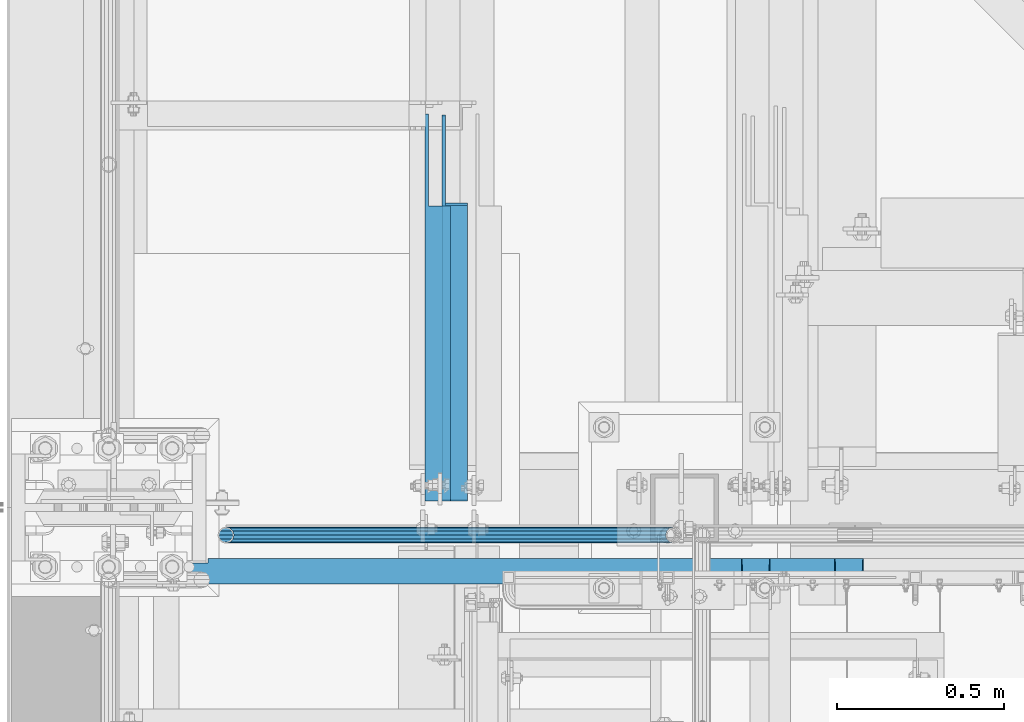
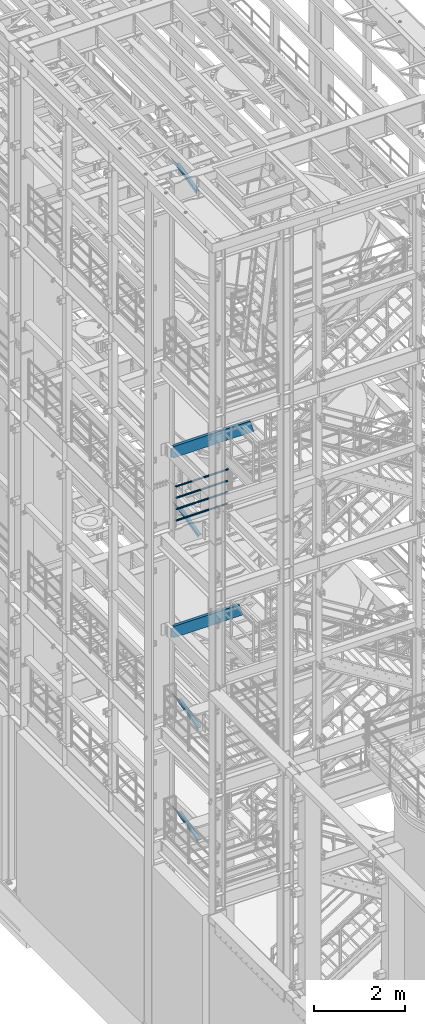
# One storey, part 963 of 1876: 10 beams, 7 elements without a shape of their own.
"""IFC2X3 building model written with IfcOpenShell, lengths in millimetres."""

from ifc_helpers import new_model, si_unit, frame, origin_with_axes, place, context, subcontext, project, spatial, faceted_brep, material, type_object, element, aggregate, save


model = new_model("IFC2X3")

# Units and contexts
model_context = context("Model", 3, precision=1e-05, world=origin_with_axes())
body_context = subcontext(model_context, "Body", "Model", "MODEL_VIEW")
ifc_project = project(units=[si_unit("LENGTHUNIT", "METRE", prefix="MILLI"), si_unit("AREAUNIT", "SQUARE_METRE"), si_unit("VOLUMEUNIT", "CUBIC_METRE"), si_unit("MASSUNIT", "GRAM", prefix="KILO"), si_unit("TIMEUNIT", "SECOND"), si_unit("PLANEANGLEUNIT", "RADIAN"), si_unit("SOLIDANGLEUNIT", "STERADIAN"), si_unit("THERMODYNAMICTEMPERATUREUNIT", "DEGREE_CELSIUS"), si_unit("LUMINOUSINTENSITYUNIT", "LUMEN")], contexts=[model_context])

# Site, building, storey
site_placement = place(None, origin_with_axes())
site = spatial("IfcSite", under=ifc_project, at=site_placement, CompositionType="ELEMENT")
building_placement = place(site_placement, origin_with_axes())
building = spatial("IfcBuilding", under=site, at=building_placement, Name="Undefined", CompositionType="ELEMENT")
storey_placement = place(building_placement, origin_with_axes())
storey = spatial("IfcBuildingStorey", under=building, at=storey_placement, Name="Undefined", CompositionType="ELEMENT", Elevation=0.0)

# Assembly, beams
assembly_1_placement = place(storey_placement, origin_with_axes())
assembly_1 = element("IfcElementAssembly", 1, at=assembly_1_placement, inside=storey, Name="RAIL", AssemblyPlace="NOTDEFINED", PredefinedType="RIGID_FRAME")
ifc_material_1 = material()
beam_type_1 = type_object("IfcBeamType", Name="PIPE1-1/2SCH40", PredefinedType="NOTDEFINED")
beam_1_placement = place(assembly_1_placement, frame((351.789999999999, -4654.55000114554, 13471.525), z_axis=(0.0, 0.0, 1.0), x_axis=(1.0, 0.0, 0.0)))
beam_1 = element("IfcBeam", 2, at=beam_1_placement, type_object=beam_type_1, material=ifc_material_1, Name="RAIL", ObjectType="PIPE1-1/2SCH40", context=body_context, shape_type="Brep", body=[
    faceted_brep([(1322.12780700668, -12.0649999999996, 20.8971929933186), (1322.12780700668, -12.0649999999996, 15.8661214311805), (1321.63437856882, -10.2235000000001, 17.7076214311801), (1318.895, 0.0, 20.4470000000001), (1318.895, 0.0, 24.1300000000001), (1321.63437856882, 10.2235000000001, 17.7076214311801), (1322.12780700668, 12.0649999999996, 15.8661214311805), (1322.12780700668, 12.0649999999996, 20.8971929933186), (1343.025, 24.1300000000001, 0.0), (1330.96, 20.8971929933186, 12.0649999999996), (1330.96, 20.8971929933186, -12.0649999999996), (1327.77042843786, 17.7076214311801, 10.2235000000001), (1330.50980700668, 20.4470000000001, 0.0), (1327.77042843786, 17.7076214311801, -10.2235000000001), (1322.12780700668, 12.0649999999996, -15.8661214311805), (1322.12780700668, 12.0649999999996, -20.8971929933186), (1321.63437856882, 10.2235000000001, -17.7076214311801), (1318.895, 0.0, -20.4470000000001), (1318.895, 0.0, -24.1300000000001), (1322.12780700668, -12.0649999999996, -15.8661214311805), (1322.12780700668, -12.0649999999996, -20.8971929933186), (1321.63437856882, -10.2235000000001, -17.7076214311801), (1343.025, -24.1300000000001, 0.0), (1330.96, -20.8971929933186, -12.0649999999996), (1330.96, -20.8971929933186, 12.0649999999996), (1327.77042843786, -17.7076214311801, -10.2235000000001), (1330.50980700668, -20.4470000000001, 0.0), (1327.77042843786, -17.7076214311801, 10.2235000000001), (12.0650000000064, -20.8971929933177, -12.0649999999987), (20.8971929933249, -12.0650000000005, -20.8971929933177), (0.0, 24.1299999999992, 0.0), (12.0650000000064, 20.8971929933177, -12.0649999999987), (12.0650000000064, 20.8971929933177, 12.0649999999987), (20.8971929933249, 12.0650000000005, 20.8971929933177), (24.1300000000064, 0.0, 24.130000000001), (20.8971929933249, 12.0650000000005, -20.8971929933177), (24.1300000000063, 0.0, -24.130000000001), (24.1300000000063, 0.0, -20.4470000000001), (20.8971929933249, -12.0650000000005, -15.8661214311796), (21.3906214311868, -10.2235000000001, -17.7076214311819), (21.3906214311868, 10.2235000000001, -17.7076214311819), (20.8971929933249, 12.0650000000005, -15.8661214311796), (15.2545715621445, 17.7076214311801, -10.2235000000001), (12.5151929933249, 20.4470000000001, 0.0), (15.2545715621445, 17.7076214311801, 10.2235000000001), (20.8971929933249, 12.0650000000005, 15.8661214311796), (21.3906214311868, 10.2235000000001, 17.7076214311819), (24.1300000000064, 0.0, 20.4470000000001), (21.3906214311868, -10.2235000000001, 17.7076214311819), (20.8971929933249, -12.0650000000005, 15.8661214311796), (20.8971929933249, -12.0650000000005, 20.8971929933177), (12.0650000000064, -20.8971929933177, 12.0649999999987), (0.0, -24.1299999999992, 0.0), (15.2545715621445, -17.7076214311801, 10.2235000000001), (12.5151929933249, -20.4470000000001, 0.0), (15.2545715621445, -17.7076214311801, -10.2235000000001)], [[[0, 1, 2, 3, 4]], [[4, 3, 5, 6, 7]], [[8, 9, 10]], [[7, 6, 11, 12, 13, 14, 15, 10, 9]], [[16, 17, 18, 15, 14]], [[19, 20, 18, 17, 21]], [[22, 23, 24]], [[24, 23, 20, 19, 25, 26, 27, 1, 0]], [[28, 29, 20, 23]], [[30, 31, 32]], [[33, 34, 4, 7]], [[32, 33, 7, 9]], [[30, 32, 9, 8]], [[31, 30, 8, 10]], [[35, 31, 10, 15]], [[36, 35, 15, 18]], [[29, 36, 18, 20]], [[37, 36, 29, 38, 39]], [[40, 41, 35, 36, 37]], [[32, 31, 35, 41, 42, 43, 44, 45, 33]], [[33, 45, 46, 47, 34]], [[34, 47, 48, 49, 50]], [[34, 50, 0, 4]], [[50, 51, 24, 0]], [[51, 52, 22, 24]], [[52, 28, 23, 22]], [[51, 28, 52]], [[50, 49, 53, 54, 55, 38, 29, 28, 51]], [[55, 54, 26, 25]], [[21, 39, 38, 55, 25, 19]], [[37, 39, 21, 17]], [[40, 37, 17, 16]], [[42, 41, 40, 16, 14, 13]], [[43, 42, 13, 12]], [[44, 43, 12, 11]], [[5, 46, 45, 44, 11, 6]], [[47, 46, 5, 3]], [[48, 47, 3, 2]], [[53, 49, 48, 2, 1, 27]], [[54, 53, 27, 26]]]),
])
beam_2_placement = place(assembly_1_placement, frame((1694.815, -4654.55000114554, 13776.325), z_axis=(0.0, 0.0, -1.0), x_axis=(-1.0, 0.0, 0.0)))
beam_2 = element("IfcBeam", 3, at=beam_2_placement, type_object=beam_type_1, material=ifc_material_1, Name="RAIL", ObjectType="PIPE1-1/2SCH40", context=body_context, shape_type="Brep", body=[
    faceted_brep([(0.0, 24.1299999999992, 0.0), (12.0650000000064, 20.8971929933177, -12.0649999999987), (12.0650000000064, 20.8971929933177, 12.0649999999987), (12.0650000000064, -20.8971929933177, 12.0649999999987), (12.0650000000064, -20.8971929933177, -12.0649999999987), (0.0, -24.1299999999992, 0.0), (20.8971929933249, -12.0650000000005, 20.8971929933177), (20.8971929933249, -12.0650000000005, 15.8661214311796), (15.2545715621445, -17.7076214311801, 10.2235000000001), (12.5151929933249, -20.4470000000001, 0.0), (15.2545715621445, -17.7076214311801, -10.2235000000001), (20.8971929933249, -12.0650000000005, -15.8661214311796), (20.8971929933249, -12.0650000000005, -20.8971929933177), (24.1300000000063, 0.0, -20.4470000000001), (24.1300000000063, 0.0, -24.130000000001), (21.3906214311868, -10.2235000000001, -17.7076214311819), (21.3906214311868, 10.2235000000001, -17.7076214311819), (20.8971929933249, 12.0650000000005, -15.8661214311796), (20.8971929933249, 12.0650000000005, -20.8971929933177), (15.2545715621445, 17.7076214311801, -10.2235000000001), (12.5151929933249, 20.4470000000001, 0.0), (15.2545715621445, 17.7076214311801, 10.2235000000001), (20.8971929933249, 12.0650000000005, 15.8661214311796), (20.8971929933249, 12.0650000000005, 20.8971929933177), (21.3906214311868, 10.2235000000001, 17.7076214311819), (24.1300000000064, 0.0, 20.4470000000001), (24.1300000000064, 0.0, 24.130000000001), (21.3906214311868, -10.2235000000001, 17.7076214311819), (1343.025, 24.1300000000001, 0.0), (1330.96, 20.8971929933186, -12.0649999999996), (1322.12780700668, 12.0649999999996, -20.8971929933186), (1343.025, -24.1300000000001, 0.0), (1330.96, -20.8971929933186, -12.0649999999996), (1330.96, -20.8971929933186, 12.0649999999996), (1322.12780700668, -12.0649999999996, 20.8971929933186), (1322.12780700668, -12.0649999999996, -20.8971929933186), (1318.895, 0.0, -24.1300000000001), (1321.63437856882, 10.2235000000001, -17.7076214311801), (1318.895, 0.0, -20.4470000000001), (1322.12780700668, 12.0649999999996, -15.8661214311805), (1322.12780700668, -12.0649999999996, -15.8661214311805), (1321.63437856882, -10.2235000000001, -17.7076214311801), (1327.77042843786, -17.7076214311801, -10.2235000000001), (1330.50980700668, -20.4470000000001, 0.0), (1327.77042843786, -17.7076214311801, 10.2235000000001), (1322.12780700668, -12.0649999999996, 15.8661214311805), (1321.63437856882, -10.2235000000001, 17.7076214311801), (1318.895, 0.0, 20.4470000000001), (1318.895, 0.0, 24.1300000000001), (1322.12780700668, 12.0649999999996, 20.8971929933186), (1330.96, 20.8971929933186, 12.0649999999996), (1322.12780700668, 12.0649999999996, 15.8661214311805), (1327.77042843786, 17.7076214311801, 10.2235000000001), (1330.50980700668, 20.4470000000001, 0.0), (1327.77042843786, 17.7076214311801, -10.2235000000001), (1321.63437856882, 10.2235000000001, 17.7076214311801)], [[[0, 1, 2]], [[3, 4, 5]], [[6, 7, 8, 9, 10, 11, 12, 4, 3]], [[13, 14, 12, 11, 15]], [[16, 17, 18, 14, 13]], [[2, 1, 18, 17, 19, 20, 21, 22, 23]], [[23, 22, 24, 25, 26]], [[26, 25, 27, 7, 6]], [[1, 0, 28, 29]], [[18, 1, 29, 30]], [[31, 32, 33]], [[6, 3, 33, 34]], [[3, 5, 31, 33]], [[5, 4, 32, 31]], [[4, 12, 35, 32]], [[12, 14, 36, 35]], [[14, 18, 30, 36]], [[37, 38, 36, 30, 39]], [[40, 35, 36, 38, 41]], [[33, 32, 35, 40, 42, 43, 44, 45, 34]], [[34, 45, 46, 47, 48]], [[26, 6, 34, 48]], [[2, 23, 49, 50]], [[23, 26, 48, 49]], [[0, 2, 50, 28]], [[28, 50, 29]], [[49, 51, 52, 53, 54, 39, 30, 29, 50]], [[48, 47, 55, 51, 49]], [[25, 24, 55, 47]], [[55, 24, 22, 21, 52, 51]], [[21, 20, 53, 52]], [[20, 19, 54, 53]], [[19, 17, 16, 37, 39, 54]], [[16, 13, 38, 37]], [[13, 15, 41, 38]], [[41, 15, 11, 10, 42, 40]], [[10, 9, 43, 42]], [[9, 8, 44, 43]], [[8, 7, 27, 46, 45, 44]], [[27, 25, 47, 46]]]),
])
beam_3_placement = place(assembly_1_placement, frame((1694.815, -4654.55000114554, 14081.125), z_axis=(0.0, 0.0, -1.0), x_axis=(-1.0, 0.0, 0.0)))
beam_3 = element("IfcBeam", 4, at=beam_3_placement, type_object=beam_type_1, material=ifc_material_1, Name="RAIL", ObjectType="PIPE1-1/2SCH40", context=body_context, shape_type="Brep", body=[
    faceted_brep([(0.0, 24.1299999999992, 0.0), (12.0650000000064, 20.8971929933177, -12.0649999999987), (12.0650000000064, 20.8971929933177, 12.0649999999987), (12.0650000000064, -20.8971929933177, 12.0649999999987), (12.0650000000064, -20.8971929933177, -12.0649999999987), (0.0, -24.1299999999992, 0.0), (20.8971929933249, -12.0650000000005, 20.8971929933177), (20.8971929933249, -12.0650000000005, 15.8661214311796), (15.2545715621445, -17.7076214311801, 10.2235000000001), (12.5151929933249, -20.4470000000001, 0.0), (15.2545715621445, -17.7076214311801, -10.2235000000001), (20.8971929933249, -12.0650000000005, -15.8661214311796), (20.8971929933249, -12.0650000000005, -20.8971929933177), (24.1300000000063, 0.0, -20.4470000000001), (24.1300000000063, 0.0, -24.130000000001), (21.3906214311868, -10.2235000000001, -17.7076214311819), (21.3906214311868, 10.2235000000001, -17.7076214311819), (20.8971929933249, 12.0650000000005, -15.8661214311796), (20.8971929933249, 12.0650000000005, -20.8971929933177), (15.2545715621445, 17.7076214311801, -10.2235000000001), (12.5151929933249, 20.4470000000001, 0.0), (15.2545715621445, 17.7076214311801, 10.2235000000001), (20.8971929933249, 12.0650000000005, 15.8661214311796), (20.8971929933249, 12.0650000000005, 20.8971929933177), (21.3906214311868, 10.2235000000001, 17.7076214311819), (24.1300000000064, 0.0, 20.4470000000001), (24.1300000000064, 0.0, 24.130000000001), (21.3906214311868, -10.2235000000001, 17.7076214311819), (1343.025, 24.1300000000001, 0.0), (1330.96, 20.8971929933186, -12.0649999999996), (1322.12780700668, 12.0649999999996, -20.8971929933186), (1343.025, -24.1300000000001, 0.0), (1330.96, -20.8971929933186, -12.0649999999996), (1330.96, -20.8971929933186, 12.0649999999996), (1322.12780700668, -12.0649999999996, 20.8971929933186), (1322.12780700668, -12.0649999999996, -20.8971929933186), (1318.895, 0.0, -24.1300000000001), (1321.63437856882, 10.2235000000001, -17.7076214311801), (1318.895, 0.0, -20.4470000000001), (1322.12780700668, 12.0649999999996, -15.8661214311805), (1322.12780700668, -12.0649999999996, -15.8661214311805), (1321.63437856882, -10.2235000000001, -17.7076214311801), (1327.77042843786, -17.7076214311801, -10.2235000000001), (1330.50980700668, -20.4470000000001, 0.0), (1327.77042843786, -17.7076214311801, 10.2235000000001), (1322.12780700668, -12.0649999999996, 15.8661214311805), (1321.63437856882, -10.2235000000001, 17.7076214311801), (1318.895, 0.0, 20.4470000000001), (1318.895, 0.0, 24.1300000000001), (1322.12780700668, 12.0649999999996, 20.8971929933186), (1330.96, 20.8971929933186, 12.0649999999996), (1322.12780700668, 12.0649999999996, 15.8661214311805), (1327.77042843786, 17.7076214311801, 10.2235000000001), (1330.50980700668, 20.4470000000001, 0.0), (1327.77042843786, 17.7076214311801, -10.2235000000001), (1321.63437856882, 10.2235000000001, 17.7076214311801)], [[[0, 1, 2]], [[3, 4, 5]], [[6, 7, 8, 9, 10, 11, 12, 4, 3]], [[13, 14, 12, 11, 15]], [[16, 17, 18, 14, 13]], [[2, 1, 18, 17, 19, 20, 21, 22, 23]], [[23, 22, 24, 25, 26]], [[26, 25, 27, 7, 6]], [[1, 0, 28, 29]], [[18, 1, 29, 30]], [[31, 32, 33]], [[6, 3, 33, 34]], [[3, 5, 31, 33]], [[5, 4, 32, 31]], [[4, 12, 35, 32]], [[12, 14, 36, 35]], [[14, 18, 30, 36]], [[37, 38, 36, 30, 39]], [[40, 35, 36, 38, 41]], [[33, 32, 35, 40, 42, 43, 44, 45, 34]], [[34, 45, 46, 47, 48]], [[26, 6, 34, 48]], [[2, 23, 49, 50]], [[23, 26, 48, 49]], [[0, 2, 50, 28]], [[28, 50, 29]], [[49, 51, 52, 53, 54, 39, 30, 29, 50]], [[48, 47, 55, 51, 49]], [[25, 24, 55, 47]], [[55, 24, 22, 21, 52, 51]], [[21, 20, 53, 52]], [[20, 19, 54, 53]], [[19, 17, 16, 37, 39, 54]], [[16, 13, 38, 37]], [[13, 15, 41, 38]], [[41, 15, 11, 10, 42, 40]], [[10, 9, 43, 42]], [[9, 8, 44, 43]], [[8, 7, 27, 46, 45, 44]], [[27, 25, 47, 46]]]),
])
beam_4_placement = place(assembly_1_placement, frame((1718.945, -4654.55000114554, 14385.925), z_axis=(0.0, 0.0, -1.0), x_axis=(-1.0, 0.0, 0.0)))
beam_4 = element("IfcBeam", 5, at=beam_4_placement, type_object=beam_type_1, material=ifc_material_1, Name="RAIL", ObjectType="PIPE1-1/2SCH40", context=body_context, shape_type="Brep", body=[
    faceted_brep([(24.1300000000001, -20.4469999999999, 0.0), (34.3535000000002, -17.7076214311803, 10.2235000000001), (1356.9315, -17.7076214311801, 10.2235000000001), (1367.155, -20.4470000000001, 0.0), (41.8376214311802, -10.2235000000001, 17.7076214311819), (1349.44737856882, -10.2235000000001, 17.7076214311801), (44.5770000000002, 0.0, 20.4470000000001), (1346.708, 0.0, 20.4470000000001), (41.8376214311802, 10.2235000000001, 17.7076214311819), (1349.44737856882, 10.2235000000001, 17.7076214311801), (34.3535000000002, 17.7076214311803, 10.2235000000001), (1356.9315, 17.7076214311801, 10.2235000000001), (24.1300000000001, 20.4469999999999, 0.0), (1367.155, 20.4470000000001, 0.0), (13.9065000000001, 17.7076214311803, -10.2235000000001), (1377.3785, 17.7076214311801, -10.2235000000001), (6.42237856882002, 10.2235000000001, -17.7076214311819), (1384.86262143118, 10.2235000000001, -17.7076214311801), (3.68299999999999, 0.0, -20.4470000000001), (1387.602, 0.0, -20.4470000000001), (6.42237856882002, -10.2235000000001, -17.7076214311819), (1384.86262143118, -10.2235000000001, -17.7076214311801), (13.9065000000001, -17.7076214311803, -10.2235000000001), (1377.3785, -17.7076214311801, -10.2235000000001), (24.1299999999854, -24.1299999999992, 0.0), (12.0650000000064, -20.8971929933177, -12.0649999999987), (1379.22, -20.8971929933186, -12.0649999999996), (1367.155, -24.1300000000001, 0.0), (3.23280700668147, -12.0650000000001, -20.8971929933177), (1388.05219299332, -12.0649999999996, -20.8971929933186), (-1.45519152283669e-11, 0.0, -24.130000000001), (1391.285, 0.0, -24.1300000000001), (3.23280700668147, 12.0650000000001, -20.8971929933177), (1388.05219299332, 12.0649999999996, -20.8971929933186), (12.0650000000064, 20.8971929933177, -12.0649999999987), (1379.22, 20.8971929933186, -12.0649999999996), (24.1300000000047, 24.1299999999992, 0.0), (1367.155, 24.1300000000001, 0.0), (36.1949999999997, 20.8971929933184, 12.0649999999987), (1355.09, 20.8971929933186, 12.0649999999996), (45.0271929933187, 12.0650000000001, 20.8971929933177), (1346.25780700668, 12.0649999999996, 20.8971929933186), (48.2600000000002, 0.0, 24.130000000001), (1343.025, 0.0, 24.1300000000001), (45.0271929933187, -12.0650000000001, 20.8971929933177), (1346.25780700668, -12.0649999999996, 20.8971929933186), (36.1949999999997, -20.8971929933184, 12.0649999999987), (1355.09, -20.8971929933186, 12.0649999999996)], [[[0, 1, 2, 3]], [[1, 4, 5, 2]], [[4, 6, 7, 5]], [[6, 8, 9, 7]], [[8, 10, 11, 9]], [[10, 12, 13, 11]], [[12, 14, 15, 13]], [[14, 16, 17, 15]], [[16, 18, 19, 17]], [[18, 20, 21, 19]], [[20, 22, 23, 21]], [[22, 0, 3, 23]], [[24, 25, 26, 27]], [[25, 28, 29, 26]], [[28, 30, 31, 29]], [[30, 32, 33, 31]], [[32, 34, 35, 33]], [[34, 36, 37, 35]], [[36, 38, 39, 37]], [[38, 40, 41, 39]], [[40, 42, 43, 41]], [[42, 44, 45, 43]], [[44, 46, 47, 45]], [[46, 24, 27, 47]], [[29, 31, 33, 35, 37, 39, 41, 43, 45, 47, 27, 26], [5, 7, 9, 11, 13, 15, 17, 19, 21, 23, 3, 2]], [[46, 44, 42, 40, 38, 36, 34, 32, 30, 28, 25, 24], [22, 20, 18, 16, 14, 12, 10, 8, 6, 4, 1, 0]]]),
])
aggregate(assembly_1, [beam_1, beam_2, beam_3, beam_4])

# Assembly, beam
assembly_2_placement = place(storey_placement, origin_with_axes())
assembly_2 = element("IfcElementAssembly", 6, at=assembly_2_placement, inside=storey, AssemblyPlace="NOTDEFINED", PredefinedType="RIGID_FRAME")
ifc_material_2 = material(Name="STEEL/A36")
beam_type_2 = type_object("IfcBeamType", Name="L3X3X3/8", PredefinedType="NOTDEFINED")
beam_5_placement = place(assembly_2_placement, frame((1038.225, -4562.63639932913, 12747.828770635), z_axis=(1.0, 0.0, 0.0), x_axis=(0.0, 0.969329745807939, 0.245763796951295)))
beam_5 = element("IfcBeam", 7, at=beam_5_placement, type_object=beam_type_2, material=ifc_material_2, ObjectType="L3X3X3/8", context=body_context, shape_type="Brep", body=[
    faceted_brep([(21.2904845664782, 38.0999999999603, -38.1), (21.2904845664782, 38.0999999999603, 38.0999999999999), (895.330267428491, 38.099999999693, 38.0999999999999), (895.330267428491, 38.099999999693, -38.1), (21.29048456648, 28.5749999999698, 38.0999999999999), (932.89831424159, 28.5749999996915, 38.0999999999999), (21.29048456648, 28.5749999999698, -28.575), (932.89831424159, 28.5749999996915, -28.575), (21.2904845664946, -38.0999999999694, -28.575), (1195.87464193328, -38.100000000326, -28.575), (21.2904845664946, -38.0999999999694, -38.1), (1195.87464193328, -38.100000000326, -38.1)], [[[0, 1, 2, 3]], [[1, 4, 5, 2]], [[4, 6, 7, 5]], [[6, 8, 9, 7]], [[8, 10, 11, 9]], [[10, 0, 3, 11]], [[5, 7, 9, 11, 3, 2]], [[10, 8, 6, 4, 1, 0]]]),
])
aggregate(assembly_2, [beam_5])

assembly_3_placement = place(storey_placement, origin_with_axes())
assembly_3 = element("IfcElementAssembly", 8, at=assembly_3_placement, inside=storey, AssemblyPlace="NOTDEFINED", PredefinedType="RIGID_FRAME")
beam_6_placement = place(assembly_3_placement, frame((1038.225, -4562.3143433578, 4558.96418871958), z_axis=(1.0, 0.0, 0.0), x_axis=(0.0, 0.967147277703795, 0.254216724922138)))
beam_6 = element("IfcBeam", 9, at=beam_6_placement, type_object=beam_type_2, material=ifc_material_2, ObjectType="L3X3X3/8", context=body_context, shape_type="Brep", body=[
    faceted_brep([(23.7928828385348, 38.099999999994, -38.1000000000004), (23.7928828385348, 38.099999999994, 38.1000000000004), (905.477403464634, 38.1000000000176, 38.1000000000004), (905.477403464634, 38.1000000000176, -38.1000000000004), (23.7809703256453, 28.5749999999953, 38.1000000000004), (941.714507152235, 28.5750000000207, 38.1000000000004), (23.7809703256453, 28.5749999999953, -28.5749999999998), (941.714507152235, 28.5750000000207, -28.5749999999998), (23.6975827354227, -38.0999999999913, -28.5749999999998), (1195.37423296544, -38.0999999999585, -28.5749999999998), (23.6975827354227, -38.0999999999913, -38.1000000000004), (1195.37423296544, -38.0999999999585, -38.1000000000004)], [[[0, 1, 2, 3]], [[1, 4, 5, 2]], [[4, 6, 7, 5]], [[6, 8, 9, 7]], [[8, 10, 11, 9]], [[10, 0, 3, 11]], [[5, 7, 9, 11, 3, 2]], [[10, 8, 6, 4, 1, 0]]]),
])
aggregate(assembly_3, [beam_6])

assembly_4_placement = place(storey_placement, origin_with_axes())
assembly_4 = element("IfcElementAssembly", 10, at=assembly_4_placement, inside=storey, AssemblyPlace="NOTDEFINED", PredefinedType="RIGID_FRAME")
beam_7_placement = place(assembly_4_placement, frame((987.425, -4562.78281844769, 21997.5317219592), z_axis=(1.0, 0.0, 0.0), x_axis=(0.0, 0.97029600569138, 0.241920774923019)))
beam_7 = element("IfcBeam", 11, at=beam_7_placement, type_object=beam_type_2, material=ifc_material_2, ObjectType="L3X3X3/8", context=body_context, shape_type="Brep", body=[
    faceted_brep([(20.4512332895073, 38.1000000000495, -38.0999999999999), (20.4512332895073, 38.1000000000495, 38.0999999999999), (892.440924395522, 38.0999999997366, 38.0999999999999), (892.440924395522, 38.0999999997366, -38.0999999999999), (20.4512332895037, 28.5750000000371, 38.0999999999999), (930.643800759319, 28.5749999997061, 38.0999999999999), (20.4512332895037, 28.5750000000371, -28.575), (930.643800759319, 28.5749999997061, -28.575), (20.4512332894728, -38.1000000000604, -28.575), (1198.0639353059, -38.1000000004824, -28.575), (20.4512332894728, -38.1000000000604, -38.0999999999999), (1198.0639353059, -38.1000000004824, -38.0999999999999)], [[[0, 1, 2, 3]], [[1, 4, 5, 2]], [[4, 6, 7, 5]], [[6, 8, 9, 7]], [[8, 10, 11, 9]], [[10, 0, 3, 11]], [[5, 7, 9, 11, 3, 2]], [[10, 8, 6, 4, 1, 0]]]),
])
aggregate(assembly_4, [beam_7])

assembly_5_placement = place(storey_placement, origin_with_axes())
assembly_5 = element("IfcElementAssembly", 12, at=assembly_5_placement, inside=storey, AssemblyPlace="NOTDEFINED", PredefinedType="RIGID_FRAME")
beam_8_placement = place(assembly_5_placement, frame((1038.22499990463, -4562.3143433578, 7581.56418871958), z_axis=(1.0, 0.0, 0.0), x_axis=(0.0, 0.967147277703795, 0.254216724922138)))
beam_8 = element("IfcBeam", 13, at=beam_8_placement, type_object=beam_type_2, material=ifc_material_2, ObjectType="L3X3X3/8", context=body_context, shape_type="Brep", body=[
    faceted_brep([(23.7928828385348, 38.099999999994, -38.1000000000004), (23.7928828385348, 38.099999999994, 38.1000000000004), (905.477403464634, 38.1000000000176, 38.1000000000004), (905.477403464634, 38.1000000000176, -38.1000000000004), (23.7809703256453, 28.5749999999953, 38.1000000000004), (941.714507152235, 28.5750000000207, 38.1000000000004), (23.7809703256453, 28.5749999999953, -28.5749999999998), (941.714507152235, 28.5750000000207, -28.5749999999998), (23.6975827354227, -38.0999999999913, -28.5749999999998), (1195.37423296544, -38.0999999999585, -28.5749999999998), (23.6975827354227, -38.0999999999913, -38.1000000000004), (1195.37423296544, -38.0999999999585, -38.1000000000004)], [[[0, 1, 2, 3]], [[1, 4, 5, 2]], [[4, 6, 7, 5]], [[6, 8, 9, 7]], [[8, 10, 11, 9]], [[10, 0, 3, 11]], [[5, 7, 9, 11, 3, 2]], [[10, 8, 6, 4, 1, 0]]]),
])
aggregate(assembly_5, [beam_8])

assembly_6_placement = place(storey_placement, origin_with_axes())
assembly_6 = element("IfcElementAssembly", 14, at=assembly_6_placement, inside=storey, Name="STRINGER", AssemblyPlace="NOTDEFINED", PredefinedType="RIGID_FRAME")
beam_type_3 = type_object("IfcBeamType", Name="C12X20.7", PredefinedType="NOTDEFINED")
beam_9_placement = place(assembly_6_placement, frame((2177.16955007345, -4762.50000114547, 15442.3768514454), z_axis=(0.0, 0.0, 1.0), x_axis=(-1.0, 0.0, 0.0)))
beam_9 = element("IfcBeam", 15, at=beam_9_placement, type_object=beam_type_3, material=ifc_material_2, Name="STRINGER", ObjectType="C12X20.7", context=body_context, shape_type="Brep", body=[
    faceted_brep([(1878.71955006828, -38.1000000000004, 152.4), (1878.71955006828, -38.1000000000004, 146.04746), (1878.71955007345, -23.8125011453449, 143.667162690814), (1878.71955007345, -23.8125011453449, 152.4), (1945.3945504157, -23.9791882336231, 152.4), (1945.3945504157, -23.9791882336231, 143.694932759721), (1878.71955006828, -38.1000000000004, -146.04746), (1878.71955006828, -38.1000000000004, -152.4), (1878.71955007345, -23.8125011453449, -152.4), (1878.71955007345, -23.8125011453449, -143.667162690814), (1945.3945504157, -23.9791882336231, -143.694932759721), (1945.3945504157, -23.9791882336231, -152.4), (1953.23447070692, 30.1625000000004, -121.616729922587), (1953.23447070692, 38.1000000000004, -121.616729922587), (1958.09455022497, 38.1000000000004, -120.65), (1958.09455022497, 30.1625000000004, -120.65), (1949.11429423877, 30.1625000000004, -124.369743823065), (1949.11429423877, 38.1000000000004, -124.369743823065), (1946.36128033829, 30.1625000000004, -128.489920291218), (1946.36128033829, 38.1000000000004, -128.489920291218), (1945.3945504157, 30.1625000000004, -133.349999809265), (1945.3945504157, 38.1000000000004, -133.349999809265), (-86.7653285857914, -38.1000000000004, -152.4), (-84.9569945646185, -38.1000000000004, -146.04746), (-81.7196536857496, 30.1625000000004, -134.6749275), (-5.04567660027396, 30.1625000000004, 134.6749275), (-1.80833572140546, -38.1000000000004, 146.04746), (0.0, -38.1000000000004, 152.4), (0.0, 38.1000000000004, 152.4), (-86.7653285857914, 38.1000000000004, -152.4), (1945.3945504157, 30.1625000000004, 134.6749275), (1945.3945504157, 38.1000000000004, 152.4), (1945.3945504157, 30.1625000000004, 133.349999809265), (1945.3945504157, 38.1000000000004, 133.349999809265), (1946.36128033829, 30.1625000000004, 128.489920291218), (1946.36128033829, 38.1000000000004, 128.489920291218), (1949.11429423877, 30.1625000000004, 124.369743823065), (1949.11429423877, 38.1000000000004, 124.369743823065), (1953.23447070692, 30.1625000000004, 121.616729922587), (1953.23447070692, 38.1000000000004, 121.616729922587), (1958.09455022497, 30.1625000000004, 120.65), (1958.09455022497, 38.1000000000004, 120.65), (2021.5945504157, 30.1625000000004, 120.65), (2021.5945504157, 38.1000000000004, 120.65), (2021.59455041571, 30.1625000000004, -120.65), (2021.59455041571, 38.1000000000004, -120.65), (1945.3945504157, 38.1000000000004, -152.4), (1945.3945504157, 30.1625000000004, -134.6749275)], [[[0, 1, 2, 3]], [[4, 3, 2, 5]], [[6, 7, 8, 9]], [[10, 9, 8, 11]], [[12, 13, 14, 15]], [[16, 17, 13, 12]], [[18, 19, 17, 16]], [[20, 21, 19, 18]], [[22, 23, 24, 25, 26, 27, 28, 29]], [[1, 26, 25, 30, 5, 2]], [[27, 26, 1, 0]], [[31, 28, 27, 0, 3, 4]], [[30, 32, 33, 31, 4, 5]], [[34, 35, 33, 32]], [[36, 37, 35, 34]], [[38, 39, 37, 36]], [[40, 41, 39, 38]], [[42, 43, 41, 40]], [[43, 42, 44, 45]], [[13, 17, 19, 21, 46, 29, 28, 31, 33, 35, 37, 39, 41, 43, 45, 14]], [[44, 15, 14, 45]], [[42, 40, 38, 36, 34, 32, 30, 25, 24, 47, 20, 18, 16, 12, 15, 44]], [[46, 21, 20, 47, 10, 11]], [[7, 22, 29, 46, 11, 8]], [[23, 22, 7, 6]], [[47, 24, 23, 6, 9, 10]]]),
])
aggregate(assembly_6, [beam_9])

assembly_7_placement = place(storey_placement, origin_with_axes())
assembly_7 = element("IfcElementAssembly", 16, at=assembly_7_placement, inside=storey, Name="STRINGER", AssemblyPlace="NOTDEFINED", PredefinedType="RIGID_FRAME")
beam_10_placement = place(assembly_7_placement, frame((1897.81304917943, -4762.50000114534, 10614.025000002), z_axis=(0.0, 0.0, 1.0), x_axis=(-1.0, 0.0, 0.0)))
beam_10 = element("IfcBeam", 17, at=beam_10_placement, type_object=beam_type_3, material=ifc_material_2, Name="STRINGER", ObjectType="C12X20.7", context=body_context, shape_type="Brep", body=[
    faceted_brep([(1666.03804952168, 30.1625000000004, -134.6749275), (1666.03804952168, -23.9791882336276, -143.694932759723), (1666.03804952168, -23.9791882336276, -152.4), (1666.03804952168, 38.1000000000004, -152.4), (1666.03804952168, 38.1000000000004, -133.349999809265), (1666.03804952168, 30.1625000000004, -133.349999809265), (1667.00477944427, 38.1000000000004, -128.489920291218), (1667.00477944427, 30.1625000000004, -128.489920291218), (1669.75779334475, 38.1000000000004, -124.369743823065), (1669.75779334475, 30.1625000000004, -124.369743823065), (1673.8779698129, 38.1000000000004, -121.616729922587), (1673.8779698129, 30.1625000000004, -121.616729922587), (1678.73804933095, 38.1000000000004, -120.65), (1678.73804933095, 30.1625000000004, -120.65), (1742.23804952168, 30.1625000000004, -120.65), (1742.23804952168, 38.1000000000004, -120.65), (1599.36304917425, -38.1000000000004, -146.04746), (1599.36304917425, -38.1000000000004, -152.4), (1599.36304917943, -23.8125011453449, -152.4), (1599.36304917943, -23.8125011453449, -143.667162690814), (-84.4459697357875, -38.1000000000004, -146.04746), (-86.2434264825929, -38.1000000000004, -152.4), (0.0, -38.1000000000004, 152.4), (-1.79745675333265, -38.1000000000004, 146.04746), (1599.36304917425, -38.1000000000004, 146.04746), (1599.36304917425, -38.1000000000004, 152.4), (1599.36304917943, -23.8125011453449, 143.667162690814), (1599.36304917943, -23.8125011453449, 152.4), (1666.03804952168, -23.9791882336276, 143.694932759723), (1666.03804952168, -23.9791882336276, 152.4), (0.0, 38.1000000000004, 152.4), (1666.03804952168, 38.1000000000004, 152.4), (-81.228101722302, 30.1625000000004, -134.6749275), (-5.01532476681837, 30.1625000000004, 134.6749275), (-86.2434264825929, 38.1000000000004, -152.4), (1666.03804952168, 30.1625000000004, 134.6749275), (1666.03804952168, 30.1625000000004, 133.349999809265), (1666.03804952168, 38.1000000000004, 133.349999809265), (1667.00477944427, 30.1625000000004, 128.489920291218), (1667.00477944427, 38.1000000000004, 128.489920291218), (1669.75779334475, 30.1625000000004, 124.369743823065), (1669.75779334475, 38.1000000000004, 124.369743823065), (1673.8779698129, 30.1625000000004, 121.616729922587), (1673.8779698129, 38.1000000000004, 121.616729922587), (1678.73804933095, 30.1625000000004, 120.65), (1678.73804933095, 38.1000000000004, 120.65), (1742.23804952168, 30.1625000000004, 120.65), (1742.23804952168, 38.1000000000004, 120.65)], [[[0, 1, 2, 3, 4, 5]], [[5, 4, 6, 7]], [[7, 6, 8, 9]], [[9, 8, 10, 11]], [[11, 10, 12, 13]], [[14, 13, 12, 15]], [[16, 17, 18, 19]], [[20, 21, 17, 16]], [[22, 23, 24, 25]], [[25, 24, 26, 27]], [[27, 26, 28, 29]], [[30, 22, 25, 27, 29, 31]], [[21, 20, 32, 33, 23, 22, 30, 34]], [[26, 24, 23, 33, 35, 28]], [[29, 28, 35, 36, 37, 31]], [[38, 39, 37, 36]], [[40, 41, 39, 38]], [[42, 43, 41, 40]], [[44, 45, 43, 42]], [[46, 47, 45, 44]], [[47, 46, 14, 15]], [[10, 8, 6, 4, 3, 34, 30, 31, 37, 39, 41, 43, 45, 47, 15, 12]], [[18, 17, 21, 34, 3, 2]], [[19, 18, 2, 1]], [[32, 20, 16, 19, 1, 0]], [[46, 44, 42, 40, 38, 36, 35, 33, 32, 0, 5, 7, 9, 11, 13, 14]]]),
])
aggregate(assembly_7, [beam_10])

save(model, "model.ifc")
